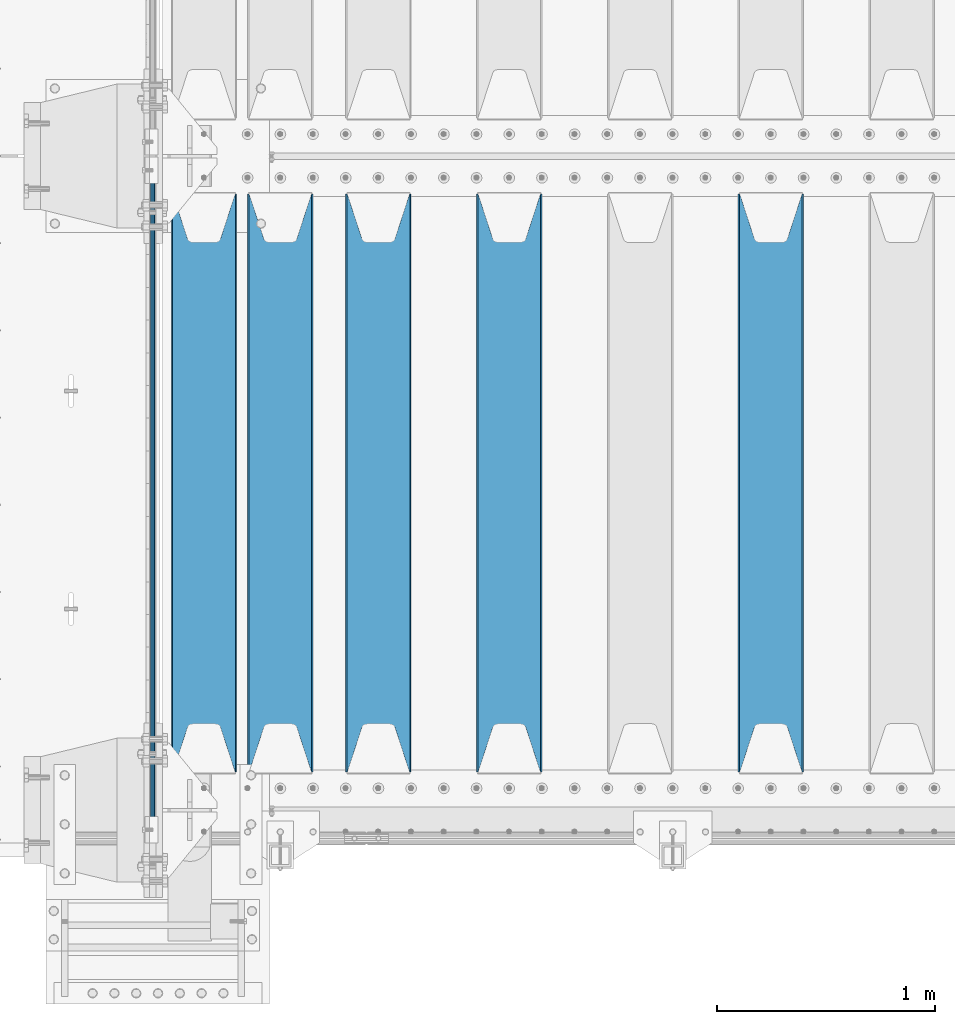
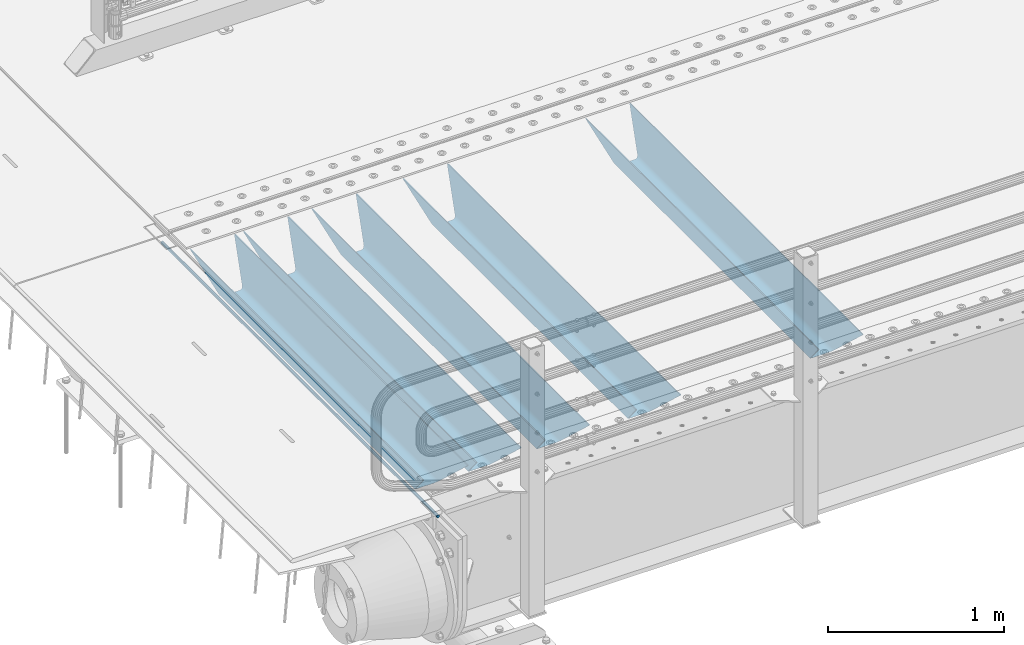
# One storey, part 90 of 208: 6 beams.
"""IFC2X3 building model written with IfcOpenShell, lengths in millimetres."""

from ifc_helpers import new_model, si_unit, frame, origin_with_axes, place, context, subcontext, project, spatial, faceted_brep, material, type_object, element, save


model = new_model("IFC2X3")

# Units and contexts
model_context = context("Model", 3, precision=1e-05, world=origin_with_axes())
body_context = subcontext(model_context, "Body", "Model", "MODEL_VIEW")
ifc_project = project(units=[si_unit("LENGTHUNIT", "METRE", prefix="MILLI"), si_unit("AREAUNIT", "SQUARE_METRE"), si_unit("VOLUMEUNIT", "CUBIC_METRE"), si_unit("MASSUNIT", "GRAM", prefix="KILO"), si_unit("TIMEUNIT", "SECOND"), si_unit("PLANEANGLEUNIT", "RADIAN"), si_unit("SOLIDANGLEUNIT", "STERADIAN"), si_unit("THERMODYNAMICTEMPERATUREUNIT", "DEGREE_CELSIUS"), si_unit("LUMINOUSINTENSITYUNIT", "LUMEN")], contexts=[model_context])

# Site, building, storey
site_placement = place(None, origin_with_axes())
site = spatial("IfcSite", under=ifc_project, at=site_placement, CompositionType="ELEMENT")
building_placement = place(site_placement, origin_with_axes())
building = spatial("IfcBuilding", under=site, at=building_placement, Name="Standard", CompositionType="ELEMENT")
storey_placement = place(building_placement, origin_with_axes())
storey = spatial("IfcBuildingStorey", under=building, at=storey_placement, Name="Undefined", CompositionType="ELEMENT", Elevation=0.0)

# Beams
ifc_material = material(Name="STEEL/S355N")
beam_type_1 = type_object("IfcBeamType", Name="D20", PredefinedType="NOTDEFINED")
beam_1_placement = place(storey_placement, frame((-42485.0, -150.000000000008, -26.0000191637567), z_axis=(0.0, 0.0, 1.0), x_axis=(0.0, 1.0, 0.0)))
element("IfcBeam", 1, at=beam_1_placement, inside=storey, type_object=beam_type_1, material=ifc_material, ObjectType="D20", context=body_context, shape_type="Brep", body=[
    faceted_brep([(0.0, -10.0, 0.0), (0.0, -7.07106781186303, -7.07106781186548), (3145.0, -7.07106781186303, -7.07106781186548), (3145.0, -10.0, 0.0), (0.0, 0.0, -10.0), (3145.0, 0.0, -10.0), (0.0, 7.07106781186303, -7.07106781186547), (3145.0, 7.07106781186303, -7.07106781186547), (0.0, 10.0, 0.0), (3145.0, 10.0, 0.0), (0.0, 7.07106781186303, 7.07106781186548), (3145.0, 7.07106781186303, 7.07106781186548), (0.0, 0.0, 10.0), (3145.0, 0.0, 10.0), (0.0, -7.07106781186303, 7.07106781186548), (3145.0, -7.07106781186303, 7.07106781186548)], [[[0, 1, 2, 3]], [[1, 4, 5, 2]], [[4, 6, 7, 5]], [[6, 8, 9, 7]], [[8, 10, 11, 9]], [[10, 12, 13, 11]], [[12, 14, 15, 13]], [[14, 0, 3, 15]], [[5, 7, 9, 11, 13, 15, 3, 2]], [[14, 12, 10, 8, 6, 4, 1, 0]]]),
])
beam_type_2 = type_object("IfcBeamType", PredefinedType="NOTDEFINED")
beam_2_placement = place(storey_placement, frame((-39650.0, 175.0, -115.0), z_axis=(0.0, 0.0, 1.0), x_axis=(0.0, 1.0, 0.0)))
element("IfcBeam", 2, at=beam_2_placement, inside=storey, type_object=beam_type_2, material=ifc_material, context=body_context, shape_type="Brep", body=[
    faceted_brep([(0.0, 150.0, 115.0), (0.0, 143.689999999999, 115.0), (2650.00000000297, 143.689999999999, 115.0), (2650.00000000297, 150.0, 115.0), (2650.00000000297, 142.059565218402, 110.0000000031), (2650.00000000297, 148.369565218403, 110.0000000031), (2441.90079219208, -80.1103600731112, -98.0992078077845), (2437.7588105432, -77.5672621345584, -102.241189456673), (2434.06523489746, -74.4080125315522, -105.934765102404), (2430.91086095089, -70.710272125576, -109.089139048974), (2428.37322971128, -66.5649389910068, -111.626770288588), (2426.51472138055, -62.0739139532889, -113.485278619323), (2425.38102192091, -57.3475956567672, -114.618978078955), (2424.99999999987, -52.5021667386536, -115.0), (2424.99999999987, 52.5021667386536, -115.0), (2425.38102192091, 57.3475956567672, -114.618978078955), (2426.51472138055, 62.0739139532889, -113.485278619323), (2428.37322971128, 66.5649389910068, -111.626770288588), (2430.91086095089, 70.710272125576, -109.089139048974), (2434.06523489746, 74.4080125315522, -105.934765102404), (2437.7588105432, 77.5672621345584, -102.241189456673), (2441.90079219208, 80.1103600731112, -98.0992078077846), (2446.38936140511, 81.9747917625791, -93.6106385947584), (2448.24948500409, 76.2713538057251, -91.7505149957729), (2444.62967112262, 74.76777986261, -95.3703288772456), (2441.28936334126, 72.7168944282894, -98.710636658607), (2438.31067330438, 70.1691124903846, -101.689326695487), (2435.76682334747, 67.1870637758839, -104.233176652398), (2433.72034654133, 63.8440531834895, -106.279653458539), (2432.22154950041, 60.222258798236, -107.778450499454), (2431.30727574265, 56.4107117849089, -108.692724257221), (2430.99999999987, 52.5031078186876, -109.0), (2430.99999999987, -52.5031078186876, -109.0), (2431.30727574265, -56.4107117849089, -108.692724257221), (2432.22154950041, -60.222258798236, -107.778450499454), (2433.72034654133, -63.8440531834895, -106.279653458539), (2435.76682334747, -67.1870637758839, -104.233176652398), (2438.31067330438, -70.1691124903846, -101.689326695487), (2441.28936334126, -72.7168944282894, -98.7106366586071), (2444.62967112262, -74.76777986261, -95.3703288772457), (2448.24948500409, -76.2713538057251, -91.7505149957729), (2650.00000000297, -142.059565218402, 110.0000000031), (2650.00000000297, -148.369565218403, 110.0000000031), (2446.38936140511, -81.9747917625791, -93.6106385947584), (2650.00000000297, -143.689999999999, 115.0), (2650.00000000297, -150.0, 115.0), (0.0, -143.689999999999, 115.0), (0.0, -150.0, 115.0), (0.0, -148.369565218261, 110.000000002663), (203.610638597421, -81.9747917625791, -93.6106385947584), (208.099207810448, -80.1103600731112, -98.0992078077845), (212.241189459336, -77.5672621345584, -102.241189456673), (215.934765105067, -74.4080125315522, -105.934765102404), (219.089139051637, -70.710272125576, -109.089139048974), (221.626770291251, -66.5649389910068, -111.626770288588), (223.485278621986, -62.0739139532889, -113.485278619323), (224.618978081618, -57.3475956567672, -114.618978078955), (225.000000002663, -52.5021667386536, -115.0), (225.000000002663, 52.5021667386536, -115.0), (224.618978081618, 57.3475956567672, -114.618978078955), (223.485278621986, 62.0739139532889, -113.485278619323), (221.626770291251, 66.5649389910068, -111.626770288588), (219.089139051637, 70.710272125576, -109.089139048974), (215.934765105067, 74.4080125315522, -105.934765102404), (212.241189459336, 77.5672621345584, -102.241189456673), (208.099207810448, 80.1103600731112, -98.0992078077846), (203.610638597421, 81.9747917625791, -93.6106385947584), (0.0, 148.369565218261, 110.000000002663), (0.0, 142.05956521826, 110.000000002663), (201.750514998436, 76.2713538057251, -91.7505149957729), (205.370328879908, 74.76777986261, -95.3703288772456), (208.71063666127, 72.7168944282894, -98.710636658607), (211.68932669815, 70.1691124903846, -101.689326695487), (214.233176655061, 67.1870637758839, -104.233176652398), (216.279653461202, 63.8440531834895, -106.279653458539), (217.778450502116, 60.222258798236, -107.778450499454), (218.692724259884, 56.4107117849089, -108.692724257221), (219.000000002663, 52.5031078186876, -109.0), (219.000000002663, -52.5031078186876, -109.0), (218.692724259884, -56.4107117849089, -108.692724257221), (217.778450502116, -60.222258798236, -107.778450499454), (216.279653461202, -63.8440531834895, -106.279653458539), (214.233176655061, -67.1870637758839, -104.233176652398), (211.68932669815, -70.1691124903846, -101.689326695487), (208.71063666127, -72.7168944282894, -98.7106366586071), (205.370328879908, -74.76777986261, -95.3703288772457), (201.750514998436, -76.2713538057251, -91.7505149957729), (0.0, -142.05956521826, 110.000000002663)], [[[0, 1, 2, 3]], [[3, 2, 4, 5]], [[6, 7, 8, 9, 10, 11, 12, 13, 14, 15, 16, 17, 18, 19, 20, 21, 22, 5, 4, 23, 24, 25, 26, 27, 28, 29, 30, 31, 32, 33, 34, 35, 36, 37, 38, 39, 40, 41, 42, 43]], [[44, 45, 42, 41]], [[46, 47, 45, 44]], [[43, 42, 45, 47, 48, 49]], [[6, 43, 49, 50]], [[7, 6, 50, 51]], [[8, 7, 51, 52]], [[9, 8, 52, 53]], [[10, 9, 53, 54]], [[11, 10, 54, 55]], [[12, 11, 55, 56]], [[13, 12, 56, 57]], [[14, 13, 57, 58]], [[15, 14, 58, 59]], [[16, 15, 59, 60]], [[17, 16, 60, 61]], [[18, 17, 61, 62]], [[19, 18, 62, 63]], [[20, 19, 63, 64]], [[21, 20, 64, 65]], [[22, 21, 65, 66]], [[0, 3, 5, 22, 66, 67]], [[1, 0, 67, 68]], [[23, 4, 2, 1, 68, 69]], [[24, 23, 69, 70]], [[25, 24, 70, 71]], [[26, 25, 71, 72]], [[27, 26, 72, 73]], [[28, 27, 73, 74]], [[29, 28, 74, 75]], [[30, 29, 75, 76]], [[31, 30, 76, 77]], [[32, 31, 77, 78]], [[33, 32, 78, 79]], [[34, 33, 79, 80]], [[35, 34, 80, 81]], [[36, 35, 81, 82]], [[37, 36, 82, 83]], [[38, 37, 83, 84]], [[39, 38, 84, 85]], [[40, 39, 85, 86]], [[46, 44, 41, 40, 86, 87]], [[47, 46, 87, 48]], [[86, 85, 84, 83, 82, 81, 80, 79, 78, 77, 76, 75, 74, 73, 72, 71, 70, 69, 68, 67, 66, 65, 64, 63, 62, 61, 60, 59, 58, 57, 56, 55, 54, 53, 52, 51, 50, 49, 48, 87]]]),
])
beam_3_placement = place(storey_placement, frame((-40850.0, 175.0, -115.0), z_axis=(0.0, 0.0, 1.0), x_axis=(0.0, 1.0, 0.0)))
element("IfcBeam", 3, at=beam_3_placement, inside=storey, type_object=beam_type_2, material=ifc_material, context=body_context, shape_type="Brep", body=[
    faceted_brep([(0.0, 150.0, 115.0), (0.0, 143.689999999999, 115.0), (2650.00000000297, 143.689999999999, 115.0), (2650.00000000297, 150.0, 115.0), (2650.00000000297, 142.059565218402, 110.0000000031), (2650.00000000297, 148.369565218403, 110.0000000031), (2441.90079219208, -80.1103600731112, -98.0992078077845), (2437.7588105432, -77.5672621345584, -102.241189456673), (2434.06523489746, -74.4080125315522, -105.934765102404), (2430.91086095089, -70.710272125576, -109.089139048974), (2428.37322971128, -66.5649389910068, -111.626770288588), (2426.51472138055, -62.0739139532889, -113.485278619323), (2425.38102192091, -57.3475956567672, -114.618978078955), (2424.99999999987, -52.5021667386536, -115.0), (2424.99999999987, 52.5021667386536, -115.0), (2425.38102192091, 57.3475956567672, -114.618978078955), (2426.51472138055, 62.0739139532889, -113.485278619323), (2428.37322971128, 66.5649389910068, -111.626770288588), (2430.91086095089, 70.710272125576, -109.089139048974), (2434.06523489746, 74.4080125315522, -105.934765102404), (2437.7588105432, 77.5672621345584, -102.241189456673), (2441.90079219208, 80.1103600731112, -98.0992078077846), (2446.38936140511, 81.9747917625791, -93.6106385947584), (2448.24948500409, 76.2713538057251, -91.7505149957729), (2444.62967112262, 74.76777986261, -95.3703288772456), (2441.28936334126, 72.7168944282894, -98.710636658607), (2438.31067330438, 70.1691124903846, -101.689326695487), (2435.76682334747, 67.1870637758839, -104.233176652398), (2433.72034654133, 63.8440531834895, -106.279653458539), (2432.22154950041, 60.222258798236, -107.778450499454), (2431.30727574265, 56.4107117849089, -108.692724257221), (2430.99999999987, 52.5031078186876, -109.0), (2430.99999999987, -52.5031078186876, -109.0), (2431.30727574265, -56.4107117849089, -108.692724257221), (2432.22154950041, -60.222258798236, -107.778450499454), (2433.72034654133, -63.8440531834895, -106.279653458539), (2435.76682334747, -67.1870637758839, -104.233176652398), (2438.31067330438, -70.1691124903846, -101.689326695487), (2441.28936334126, -72.7168944282894, -98.7106366586071), (2444.62967112262, -74.76777986261, -95.3703288772457), (2448.24948500409, -76.2713538057251, -91.7505149957729), (2650.00000000297, -142.059565218402, 110.0000000031), (2650.00000000297, -148.369565218403, 110.0000000031), (2446.38936140511, -81.9747917625791, -93.6106385947584), (2650.00000000297, -143.689999999999, 115.0), (2650.00000000297, -150.0, 115.0), (0.0, -143.689999999999, 115.0), (0.0, -150.0, 115.0), (0.0, -148.369565218261, 110.000000002663), (203.610638597421, -81.9747917625791, -93.6106385947584), (208.099207810448, -80.1103600731112, -98.0992078077845), (212.241189459336, -77.5672621345584, -102.241189456673), (215.934765105067, -74.4080125315522, -105.934765102404), (219.089139051637, -70.710272125576, -109.089139048974), (221.626770291251, -66.5649389910068, -111.626770288588), (223.485278621986, -62.0739139532889, -113.485278619323), (224.618978081618, -57.3475956567672, -114.618978078955), (225.000000002663, -52.5021667386536, -115.0), (225.000000002663, 52.5021667386536, -115.0), (224.618978081618, 57.3475956567672, -114.618978078955), (223.485278621986, 62.0739139532889, -113.485278619323), (221.626770291251, 66.5649389910068, -111.626770288588), (219.089139051637, 70.710272125576, -109.089139048974), (215.934765105067, 74.4080125315522, -105.934765102404), (212.241189459336, 77.5672621345584, -102.241189456673), (208.099207810448, 80.1103600731112, -98.0992078077846), (203.610638597421, 81.9747917625791, -93.6106385947584), (0.0, 148.369565218261, 110.000000002663), (0.0, 142.05956521826, 110.000000002663), (201.750514998436, 76.2713538057251, -91.7505149957729), (205.370328879908, 74.76777986261, -95.3703288772456), (208.71063666127, 72.7168944282894, -98.710636658607), (211.68932669815, 70.1691124903846, -101.689326695487), (214.233176655061, 67.1870637758839, -104.233176652398), (216.279653461202, 63.8440531834895, -106.279653458539), (217.778450502116, 60.222258798236, -107.778450499454), (218.692724259884, 56.4107117849089, -108.692724257221), (219.000000002663, 52.5031078186876, -109.0), (219.000000002663, -52.5031078186876, -109.0), (218.692724259884, -56.4107117849089, -108.692724257221), (217.778450502116, -60.222258798236, -107.778450499454), (216.279653461202, -63.8440531834895, -106.279653458539), (214.233176655061, -67.1870637758839, -104.233176652398), (211.68932669815, -70.1691124903846, -101.689326695487), (208.71063666127, -72.7168944282894, -98.7106366586071), (205.370328879908, -74.76777986261, -95.3703288772457), (201.750514998436, -76.2713538057251, -91.7505149957729), (0.0, -142.05956521826, 110.000000002663)], [[[0, 1, 2, 3]], [[3, 2, 4, 5]], [[6, 7, 8, 9, 10, 11, 12, 13, 14, 15, 16, 17, 18, 19, 20, 21, 22, 5, 4, 23, 24, 25, 26, 27, 28, 29, 30, 31, 32, 33, 34, 35, 36, 37, 38, 39, 40, 41, 42, 43]], [[44, 45, 42, 41]], [[46, 47, 45, 44]], [[43, 42, 45, 47, 48, 49]], [[6, 43, 49, 50]], [[7, 6, 50, 51]], [[8, 7, 51, 52]], [[9, 8, 52, 53]], [[10, 9, 53, 54]], [[11, 10, 54, 55]], [[12, 11, 55, 56]], [[13, 12, 56, 57]], [[14, 13, 57, 58]], [[15, 14, 58, 59]], [[16, 15, 59, 60]], [[17, 16, 60, 61]], [[18, 17, 61, 62]], [[19, 18, 62, 63]], [[20, 19, 63, 64]], [[21, 20, 64, 65]], [[22, 21, 65, 66]], [[0, 3, 5, 22, 66, 67]], [[1, 0, 67, 68]], [[23, 4, 2, 1, 68, 69]], [[24, 23, 69, 70]], [[25, 24, 70, 71]], [[26, 25, 71, 72]], [[27, 26, 72, 73]], [[28, 27, 73, 74]], [[29, 28, 74, 75]], [[30, 29, 75, 76]], [[31, 30, 76, 77]], [[32, 31, 77, 78]], [[33, 32, 78, 79]], [[34, 33, 79, 80]], [[35, 34, 80, 81]], [[36, 35, 81, 82]], [[37, 36, 82, 83]], [[38, 37, 83, 84]], [[39, 38, 84, 85]], [[40, 39, 85, 86]], [[46, 44, 41, 40, 86, 87]], [[47, 46, 87, 48]], [[86, 85, 84, 83, 82, 81, 80, 79, 78, 77, 76, 75, 74, 73, 72, 71, 70, 69, 68, 67, 66, 65, 64, 63, 62, 61, 60, 59, 58, 57, 56, 55, 54, 53, 52, 51, 50, 49, 48, 87]]]),
])
beam_4_placement = place(storey_placement, frame((-41450.0, 175.0, -115.0), z_axis=(0.0, 0.0, 1.0), x_axis=(0.0, 1.0, 0.0)))
element("IfcBeam", 4, at=beam_4_placement, inside=storey, type_object=beam_type_2, material=ifc_material, context=body_context, shape_type="Brep", body=[
    faceted_brep([(0.0, 150.0, 115.0), (0.0, 143.689999999999, 115.0), (2650.00000000297, 143.689999999999, 115.0), (2650.00000000297, 150.0, 115.0), (2650.00000000297, 142.059565218402, 110.0000000031), (2650.00000000297, 148.369565218403, 110.0000000031), (2441.90079219208, -80.1103600731112, -98.0992078077845), (2437.7588105432, -77.5672621345584, -102.241189456673), (2434.06523489746, -74.4080125315522, -105.934765102404), (2430.91086095089, -70.710272125576, -109.089139048974), (2428.37322971128, -66.5649389910068, -111.626770288588), (2426.51472138055, -62.0739139532889, -113.485278619323), (2425.38102192091, -57.3475956567672, -114.618978078955), (2424.99999999987, -52.5021667386536, -115.0), (2424.99999999987, 52.5021667386536, -115.0), (2425.38102192091, 57.3475956567672, -114.618978078955), (2426.51472138055, 62.0739139532889, -113.485278619323), (2428.37322971128, 66.5649389910068, -111.626770288588), (2430.91086095089, 70.710272125576, -109.089139048974), (2434.06523489746, 74.4080125315522, -105.934765102404), (2437.7588105432, 77.5672621345584, -102.241189456673), (2441.90079219208, 80.1103600731112, -98.0992078077846), (2446.38936140511, 81.9747917625791, -93.6106385947584), (2448.24948500409, 76.2713538057251, -91.7505149957729), (2444.62967112262, 74.76777986261, -95.3703288772456), (2441.28936334126, 72.7168944282894, -98.710636658607), (2438.31067330438, 70.1691124903846, -101.689326695487), (2435.76682334747, 67.1870637758839, -104.233176652398), (2433.72034654133, 63.8440531834895, -106.279653458539), (2432.22154950041, 60.222258798236, -107.778450499454), (2431.30727574265, 56.4107117849089, -108.692724257221), (2430.99999999987, 52.5031078186876, -109.0), (2430.99999999987, -52.5031078186876, -109.0), (2431.30727574265, -56.4107117849089, -108.692724257221), (2432.22154950041, -60.222258798236, -107.778450499454), (2433.72034654133, -63.8440531834895, -106.279653458539), (2435.76682334747, -67.1870637758839, -104.233176652398), (2438.31067330438, -70.1691124903846, -101.689326695487), (2441.28936334126, -72.7168944282894, -98.7106366586071), (2444.62967112262, -74.76777986261, -95.3703288772457), (2448.24948500409, -76.2713538057251, -91.7505149957729), (2650.00000000297, -142.059565218402, 110.0000000031), (2650.00000000297, -148.369565218403, 110.0000000031), (2446.38936140511, -81.9747917625791, -93.6106385947584), (2650.00000000297, -143.689999999999, 115.0), (2650.00000000297, -150.0, 115.0), (0.0, -143.689999999999, 115.0), (0.0, -150.0, 115.0), (0.0, -148.369565218261, 110.000000002663), (203.610638597421, -81.9747917625791, -93.6106385947584), (208.099207810448, -80.1103600731112, -98.0992078077845), (212.241189459336, -77.5672621345584, -102.241189456673), (215.934765105067, -74.4080125315522, -105.934765102404), (219.089139051637, -70.710272125576, -109.089139048974), (221.626770291251, -66.5649389910068, -111.626770288588), (223.485278621986, -62.0739139532889, -113.485278619323), (224.618978081618, -57.3475956567672, -114.618978078955), (225.000000002663, -52.5021667386536, -115.0), (225.000000002663, 52.5021667386536, -115.0), (224.618978081618, 57.3475956567672, -114.618978078955), (223.485278621986, 62.0739139532889, -113.485278619323), (221.626770291251, 66.5649389910068, -111.626770288588), (219.089139051637, 70.710272125576, -109.089139048974), (215.934765105067, 74.4080125315522, -105.934765102404), (212.241189459336, 77.5672621345584, -102.241189456673), (208.099207810448, 80.1103600731112, -98.0992078077846), (203.610638597421, 81.9747917625791, -93.6106385947584), (0.0, 148.369565218261, 110.000000002663), (0.0, 142.05956521826, 110.000000002663), (201.750514998436, 76.2713538057251, -91.7505149957729), (205.370328879908, 74.76777986261, -95.3703288772456), (208.71063666127, 72.7168944282894, -98.710636658607), (211.68932669815, 70.1691124903846, -101.689326695487), (214.233176655061, 67.1870637758839, -104.233176652398), (216.279653461202, 63.8440531834895, -106.279653458539), (217.778450502116, 60.222258798236, -107.778450499454), (218.692724259884, 56.4107117849089, -108.692724257221), (219.000000002663, 52.5031078186876, -109.0), (219.000000002663, -52.5031078186876, -109.0), (218.692724259884, -56.4107117849089, -108.692724257221), (217.778450502116, -60.222258798236, -107.778450499454), (216.279653461202, -63.8440531834895, -106.279653458539), (214.233176655061, -67.1870637758839, -104.233176652398), (211.68932669815, -70.1691124903846, -101.689326695487), (208.71063666127, -72.7168944282894, -98.7106366586071), (205.370328879908, -74.76777986261, -95.3703288772457), (201.750514998436, -76.2713538057251, -91.7505149957729), (0.0, -142.05956521826, 110.000000002663)], [[[0, 1, 2, 3]], [[3, 2, 4, 5]], [[6, 7, 8, 9, 10, 11, 12, 13, 14, 15, 16, 17, 18, 19, 20, 21, 22, 5, 4, 23, 24, 25, 26, 27, 28, 29, 30, 31, 32, 33, 34, 35, 36, 37, 38, 39, 40, 41, 42, 43]], [[44, 45, 42, 41]], [[46, 47, 45, 44]], [[43, 42, 45, 47, 48, 49]], [[6, 43, 49, 50]], [[7, 6, 50, 51]], [[8, 7, 51, 52]], [[9, 8, 52, 53]], [[10, 9, 53, 54]], [[11, 10, 54, 55]], [[12, 11, 55, 56]], [[13, 12, 56, 57]], [[14, 13, 57, 58]], [[15, 14, 58, 59]], [[16, 15, 59, 60]], [[17, 16, 60, 61]], [[18, 17, 61, 62]], [[19, 18, 62, 63]], [[20, 19, 63, 64]], [[21, 20, 64, 65]], [[22, 21, 65, 66]], [[0, 3, 5, 22, 66, 67]], [[1, 0, 67, 68]], [[23, 4, 2, 1, 68, 69]], [[24, 23, 69, 70]], [[25, 24, 70, 71]], [[26, 25, 71, 72]], [[27, 26, 72, 73]], [[28, 27, 73, 74]], [[29, 28, 74, 75]], [[30, 29, 75, 76]], [[31, 30, 76, 77]], [[32, 31, 77, 78]], [[33, 32, 78, 79]], [[34, 33, 79, 80]], [[35, 34, 80, 81]], [[36, 35, 81, 82]], [[37, 36, 82, 83]], [[38, 37, 83, 84]], [[39, 38, 84, 85]], [[40, 39, 85, 86]], [[46, 44, 41, 40, 86, 87]], [[47, 46, 87, 48]], [[86, 85, 84, 83, 82, 81, 80, 79, 78, 77, 76, 75, 74, 73, 72, 71, 70, 69, 68, 67, 66, 65, 64, 63, 62, 61, 60, 59, 58, 57, 56, 55, 54, 53, 52, 51, 50, 49, 48, 87]]]),
])
beam_5_placement = place(storey_placement, frame((-41900.0, 175.0, -115.0), z_axis=(0.0, 0.0, 1.0), x_axis=(0.0, 1.0, 0.0)))
element("IfcBeam", 5, at=beam_5_placement, inside=storey, type_object=beam_type_2, material=ifc_material, context=body_context, shape_type="Brep", body=[
    faceted_brep([(0.0, 150.0, 115.0), (0.0, 143.689999999999, 115.0), (2650.00000000297, 143.689999999999, 115.0), (2650.00000000297, 150.0, 115.0), (2650.00000000297, 142.059565218402, 110.0000000031), (2650.00000000297, 148.369565218403, 110.0000000031), (2441.90079219208, -80.1103600731112, -98.0992078077845), (2437.7588105432, -77.5672621345584, -102.241189456673), (2434.06523489746, -74.4080125315522, -105.934765102404), (2430.91086095089, -70.710272125576, -109.089139048974), (2428.37322971128, -66.5649389910068, -111.626770288588), (2426.51472138055, -62.0739139532889, -113.485278619323), (2425.38102192091, -57.3475956567672, -114.618978078955), (2424.99999999987, -52.5021667386536, -115.0), (2424.99999999987, 52.5021667386536, -115.0), (2425.38102192091, 57.3475956567672, -114.618978078955), (2426.51472138055, 62.0739139532889, -113.485278619323), (2428.37322971128, 66.5649389910068, -111.626770288588), (2430.91086095089, 70.710272125576, -109.089139048974), (2434.06523489746, 74.4080125315522, -105.934765102404), (2437.7588105432, 77.5672621345584, -102.241189456673), (2441.90079219208, 80.1103600731112, -98.0992078077846), (2446.38936140511, 81.9747917625791, -93.6106385947584), (2448.24948500409, 76.2713538057251, -91.7505149957729), (2444.62967112262, 74.76777986261, -95.3703288772456), (2441.28936334126, 72.7168944282894, -98.710636658607), (2438.31067330438, 70.1691124903846, -101.689326695487), (2435.76682334747, 67.1870637758839, -104.233176652398), (2433.72034654133, 63.8440531834895, -106.279653458539), (2432.22154950041, 60.222258798236, -107.778450499454), (2431.30727574265, 56.4107117849089, -108.692724257221), (2430.99999999987, 52.5031078186876, -109.0), (2430.99999999987, -52.5031078186876, -109.0), (2431.30727574265, -56.4107117849089, -108.692724257221), (2432.22154950041, -60.222258798236, -107.778450499454), (2433.72034654133, -63.8440531834895, -106.279653458539), (2435.76682334747, -67.1870637758839, -104.233176652398), (2438.31067330438, -70.1691124903846, -101.689326695487), (2441.28936334126, -72.7168944282894, -98.7106366586071), (2444.62967112262, -74.76777986261, -95.3703288772457), (2448.24948500409, -76.2713538057251, -91.7505149957729), (2650.00000000297, -142.059565218402, 110.0000000031), (2650.00000000297, -148.369565218403, 110.0000000031), (2446.38936140511, -81.9747917625791, -93.6106385947584), (2650.00000000297, -143.689999999999, 115.0), (2650.00000000297, -150.0, 115.0), (0.0, -143.689999999999, 115.0), (0.0, -150.0, 115.0), (0.0, -148.369565218261, 110.000000002663), (203.610638597421, -81.9747917625791, -93.6106385947584), (208.099207810448, -80.1103600731112, -98.0992078077845), (212.241189459336, -77.5672621345584, -102.241189456673), (215.934765105067, -74.4080125315522, -105.934765102404), (219.089139051637, -70.710272125576, -109.089139048974), (221.626770291251, -66.5649389910068, -111.626770288588), (223.485278621986, -62.0739139532889, -113.485278619323), (224.618978081618, -57.3475956567672, -114.618978078955), (225.000000002663, -52.5021667386536, -115.0), (225.000000002663, 52.5021667386536, -115.0), (224.618978081618, 57.3475956567672, -114.618978078955), (223.485278621986, 62.0739139532889, -113.485278619323), (221.626770291251, 66.5649389910068, -111.626770288588), (219.089139051637, 70.710272125576, -109.089139048974), (215.934765105067, 74.4080125315522, -105.934765102404), (212.241189459336, 77.5672621345584, -102.241189456673), (208.099207810448, 80.1103600731112, -98.0992078077846), (203.610638597421, 81.9747917625791, -93.6106385947584), (0.0, 148.369565218261, 110.000000002663), (0.0, 142.05956521826, 110.000000002663), (201.750514998436, 76.2713538057251, -91.7505149957729), (205.370328879908, 74.76777986261, -95.3703288772456), (208.71063666127, 72.7168944282894, -98.710636658607), (211.68932669815, 70.1691124903846, -101.689326695487), (214.233176655061, 67.1870637758839, -104.233176652398), (216.279653461202, 63.8440531834895, -106.279653458539), (217.778450502116, 60.222258798236, -107.778450499454), (218.692724259884, 56.4107117849089, -108.692724257221), (219.000000002663, 52.5031078186876, -109.0), (219.000000002663, -52.5031078186876, -109.0), (218.692724259884, -56.4107117849089, -108.692724257221), (217.778450502116, -60.222258798236, -107.778450499454), (216.279653461202, -63.8440531834895, -106.279653458539), (214.233176655061, -67.1870637758839, -104.233176652398), (211.68932669815, -70.1691124903846, -101.689326695487), (208.71063666127, -72.7168944282894, -98.7106366586071), (205.370328879908, -74.76777986261, -95.3703288772457), (201.750514998436, -76.2713538057251, -91.7505149957729), (0.0, -142.05956521826, 110.000000002663)], [[[0, 1, 2, 3]], [[3, 2, 4, 5]], [[6, 7, 8, 9, 10, 11, 12, 13, 14, 15, 16, 17, 18, 19, 20, 21, 22, 5, 4, 23, 24, 25, 26, 27, 28, 29, 30, 31, 32, 33, 34, 35, 36, 37, 38, 39, 40, 41, 42, 43]], [[44, 45, 42, 41]], [[46, 47, 45, 44]], [[43, 42, 45, 47, 48, 49]], [[6, 43, 49, 50]], [[7, 6, 50, 51]], [[8, 7, 51, 52]], [[9, 8, 52, 53]], [[10, 9, 53, 54]], [[11, 10, 54, 55]], [[12, 11, 55, 56]], [[13, 12, 56, 57]], [[14, 13, 57, 58]], [[15, 14, 58, 59]], [[16, 15, 59, 60]], [[17, 16, 60, 61]], [[18, 17, 61, 62]], [[19, 18, 62, 63]], [[20, 19, 63, 64]], [[21, 20, 64, 65]], [[22, 21, 65, 66]], [[0, 3, 5, 22, 66, 67]], [[1, 0, 67, 68]], [[23, 4, 2, 1, 68, 69]], [[24, 23, 69, 70]], [[25, 24, 70, 71]], [[26, 25, 71, 72]], [[27, 26, 72, 73]], [[28, 27, 73, 74]], [[29, 28, 74, 75]], [[30, 29, 75, 76]], [[31, 30, 76, 77]], [[32, 31, 77, 78]], [[33, 32, 78, 79]], [[34, 33, 79, 80]], [[35, 34, 80, 81]], [[36, 35, 81, 82]], [[37, 36, 82, 83]], [[38, 37, 83, 84]], [[39, 38, 84, 85]], [[40, 39, 85, 86]], [[46, 44, 41, 40, 86, 87]], [[47, 46, 87, 48]], [[86, 85, 84, 83, 82, 81, 80, 79, 78, 77, 76, 75, 74, 73, 72, 71, 70, 69, 68, 67, 66, 65, 64, 63, 62, 61, 60, 59, 58, 57, 56, 55, 54, 53, 52, 51, 50, 49, 48, 87]]]),
])
beam_6_placement = place(storey_placement, frame((-42250.0, 175.0, -115.0), z_axis=(0.0, 0.0, 1.0), x_axis=(0.0, 1.0, 0.0)))
element("IfcBeam", 6, at=beam_6_placement, inside=storey, type_object=beam_type_2, material=ifc_material, context=body_context, shape_type="Brep", body=[
    faceted_brep([(0.0, 150.0, 115.0), (0.0, 143.689999999999, 115.0), (2650.00000000297, 143.689999999999, 115.0), (2650.00000000297, 150.0, 115.0), (2650.00000000297, 142.059565218402, 110.0000000031), (2650.00000000297, 148.369565218403, 110.0000000031), (2441.90079219208, -80.1103600731112, -98.0992078077845), (2437.7588105432, -77.5672621345584, -102.241189456673), (2434.06523489746, -74.4080125315522, -105.934765102404), (2430.91086095089, -70.710272125576, -109.089139048974), (2428.37322971128, -66.5649389910068, -111.626770288588), (2426.51472138055, -62.0739139532889, -113.485278619323), (2425.38102192091, -57.3475956567672, -114.618978078955), (2424.99999999987, -52.5021667386536, -115.0), (2424.99999999987, 52.5021667386536, -115.0), (2425.38102192091, 57.3475956567672, -114.618978078955), (2426.51472138055, 62.0739139532889, -113.485278619323), (2428.37322971128, 66.5649389910068, -111.626770288588), (2430.91086095089, 70.710272125576, -109.089139048974), (2434.06523489746, 74.4080125315522, -105.934765102404), (2437.7588105432, 77.5672621345584, -102.241189456673), (2441.90079219208, 80.1103600731112, -98.0992078077846), (2446.38936140511, 81.9747917625791, -93.6106385947584), (2448.24948500409, 76.2713538057251, -91.7505149957729), (2444.62967112262, 74.76777986261, -95.3703288772456), (2441.28936334126, 72.7168944282894, -98.710636658607), (2438.31067330438, 70.1691124903846, -101.689326695487), (2435.76682334747, 67.1870637758839, -104.233176652398), (2433.72034654133, 63.8440531834895, -106.279653458539), (2432.22154950041, 60.222258798236, -107.778450499454), (2431.30727574265, 56.4107117849089, -108.692724257221), (2430.99999999987, 52.5031078186876, -109.0), (2430.99999999987, -52.5031078186876, -109.0), (2431.30727574265, -56.4107117849089, -108.692724257221), (2432.22154950041, -60.222258798236, -107.778450499454), (2433.72034654133, -63.8440531834895, -106.279653458539), (2435.76682334747, -67.1870637758839, -104.233176652398), (2438.31067330438, -70.1691124903846, -101.689326695487), (2441.28936334126, -72.7168944282894, -98.7106366586071), (2444.62967112262, -74.76777986261, -95.3703288772457), (2448.24948500409, -76.2713538057251, -91.7505149957729), (2650.00000000297, -142.059565218402, 110.0000000031), (2650.00000000297, -148.369565218403, 110.0000000031), (2446.38936140511, -81.9747917625791, -93.6106385947584), (2650.00000000297, -143.689999999999, 115.0), (2650.00000000297, -150.0, 115.0), (0.0, -143.689999999999, 115.0), (0.0, -150.0, 115.0), (0.0, -148.369565218261, 110.000000002663), (203.610638597421, -81.9747917625791, -93.6106385947584), (208.099207810448, -80.1103600731112, -98.0992078077845), (212.241189459336, -77.5672621345584, -102.241189456673), (215.934765105067, -74.4080125315522, -105.934765102404), (219.089139051637, -70.710272125576, -109.089139048974), (221.626770291251, -66.5649389910068, -111.626770288588), (223.485278621986, -62.0739139532889, -113.485278619323), (224.618978081618, -57.3475956567672, -114.618978078955), (225.000000002663, -52.5021667386536, -115.0), (225.000000002663, 52.5021667386536, -115.0), (224.618978081618, 57.3475956567672, -114.618978078955), (223.485278621986, 62.0739139532889, -113.485278619323), (221.626770291251, 66.5649389910068, -111.626770288588), (219.089139051637, 70.710272125576, -109.089139048974), (215.934765105067, 74.4080125315522, -105.934765102404), (212.241189459336, 77.5672621345584, -102.241189456673), (208.099207810448, 80.1103600731112, -98.0992078077846), (203.610638597421, 81.9747917625791, -93.6106385947584), (0.0, 148.369565218261, 110.000000002663), (0.0, 142.05956521826, 110.000000002663), (201.750514998436, 76.2713538057251, -91.7505149957729), (205.370328879908, 74.76777986261, -95.3703288772456), (208.71063666127, 72.7168944282894, -98.710636658607), (211.68932669815, 70.1691124903846, -101.689326695487), (214.233176655061, 67.1870637758839, -104.233176652398), (216.279653461202, 63.8440531834895, -106.279653458539), (217.778450502116, 60.222258798236, -107.778450499454), (218.692724259884, 56.4107117849089, -108.692724257221), (219.000000002663, 52.5031078186876, -109.0), (219.000000002663, -52.5031078186876, -109.0), (218.692724259884, -56.4107117849089, -108.692724257221), (217.778450502116, -60.222258798236, -107.778450499454), (216.279653461202, -63.8440531834895, -106.279653458539), (214.233176655061, -67.1870637758839, -104.233176652398), (211.68932669815, -70.1691124903846, -101.689326695487), (208.71063666127, -72.7168944282894, -98.7106366586071), (205.370328879908, -74.76777986261, -95.3703288772457), (201.750514998436, -76.2713538057251, -91.7505149957729), (0.0, -142.05956521826, 110.000000002663)], [[[0, 1, 2, 3]], [[3, 2, 4, 5]], [[6, 7, 8, 9, 10, 11, 12, 13, 14, 15, 16, 17, 18, 19, 20, 21, 22, 5, 4, 23, 24, 25, 26, 27, 28, 29, 30, 31, 32, 33, 34, 35, 36, 37, 38, 39, 40, 41, 42, 43]], [[44, 45, 42, 41]], [[46, 47, 45, 44]], [[43, 42, 45, 47, 48, 49]], [[6, 43, 49, 50]], [[7, 6, 50, 51]], [[8, 7, 51, 52]], [[9, 8, 52, 53]], [[10, 9, 53, 54]], [[11, 10, 54, 55]], [[12, 11, 55, 56]], [[13, 12, 56, 57]], [[14, 13, 57, 58]], [[15, 14, 58, 59]], [[16, 15, 59, 60]], [[17, 16, 60, 61]], [[18, 17, 61, 62]], [[19, 18, 62, 63]], [[20, 19, 63, 64]], [[21, 20, 64, 65]], [[22, 21, 65, 66]], [[0, 3, 5, 22, 66, 67]], [[1, 0, 67, 68]], [[23, 4, 2, 1, 68, 69]], [[24, 23, 69, 70]], [[25, 24, 70, 71]], [[26, 25, 71, 72]], [[27, 26, 72, 73]], [[28, 27, 73, 74]], [[29, 28, 74, 75]], [[30, 29, 75, 76]], [[31, 30, 76, 77]], [[32, 31, 77, 78]], [[33, 32, 78, 79]], [[34, 33, 79, 80]], [[35, 34, 80, 81]], [[36, 35, 81, 82]], [[37, 36, 82, 83]], [[38, 37, 83, 84]], [[39, 38, 84, 85]], [[40, 39, 85, 86]], [[46, 44, 41, 40, 86, 87]], [[47, 46, 87, 48]], [[86, 85, 84, 83, 82, 81, 80, 79, 78, 77, 76, 75, 74, 73, 72, 71, 70, 69, 68, 67, 66, 65, 64, 63, 62, 61, 60, 59, 58, 57, 56, 55, 54, 53, 52, 51, 50, 49, 48, 87]]]),
])

save(model, "model.ifc")
